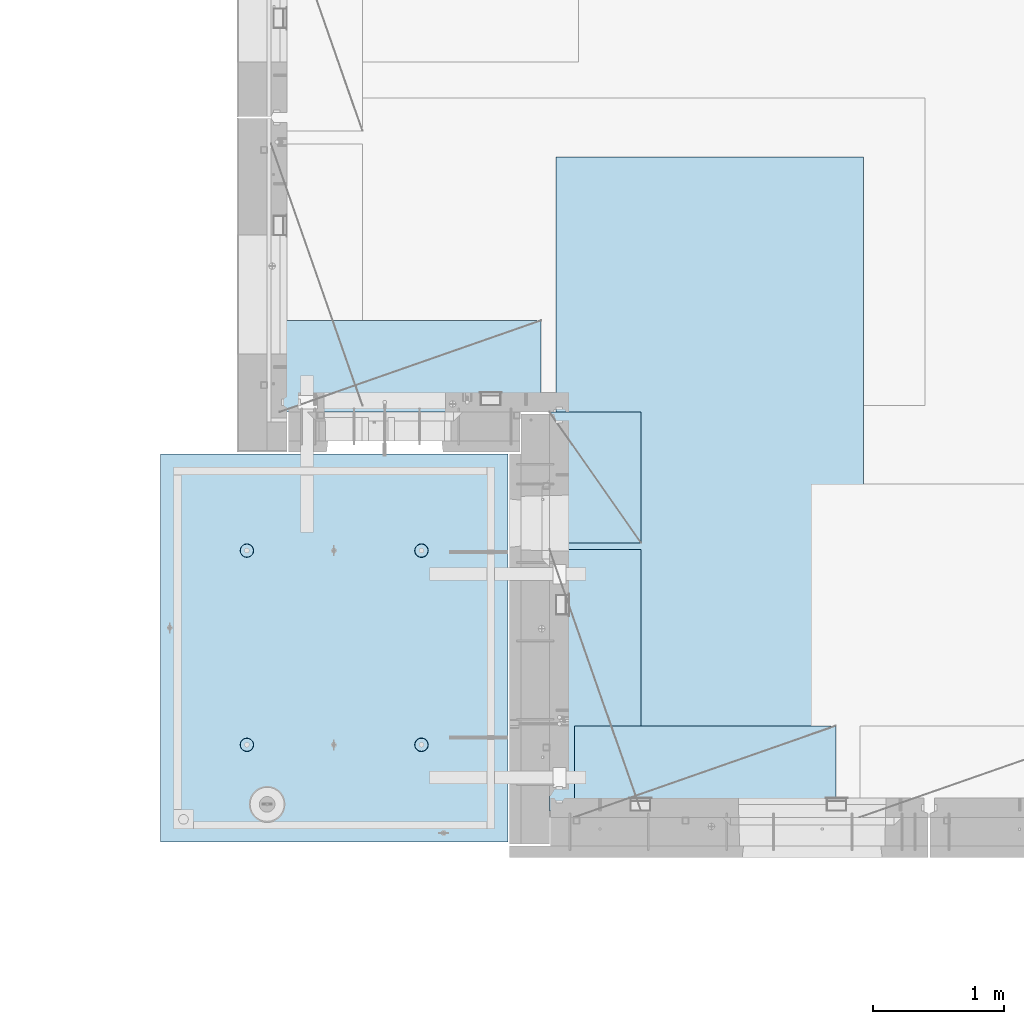
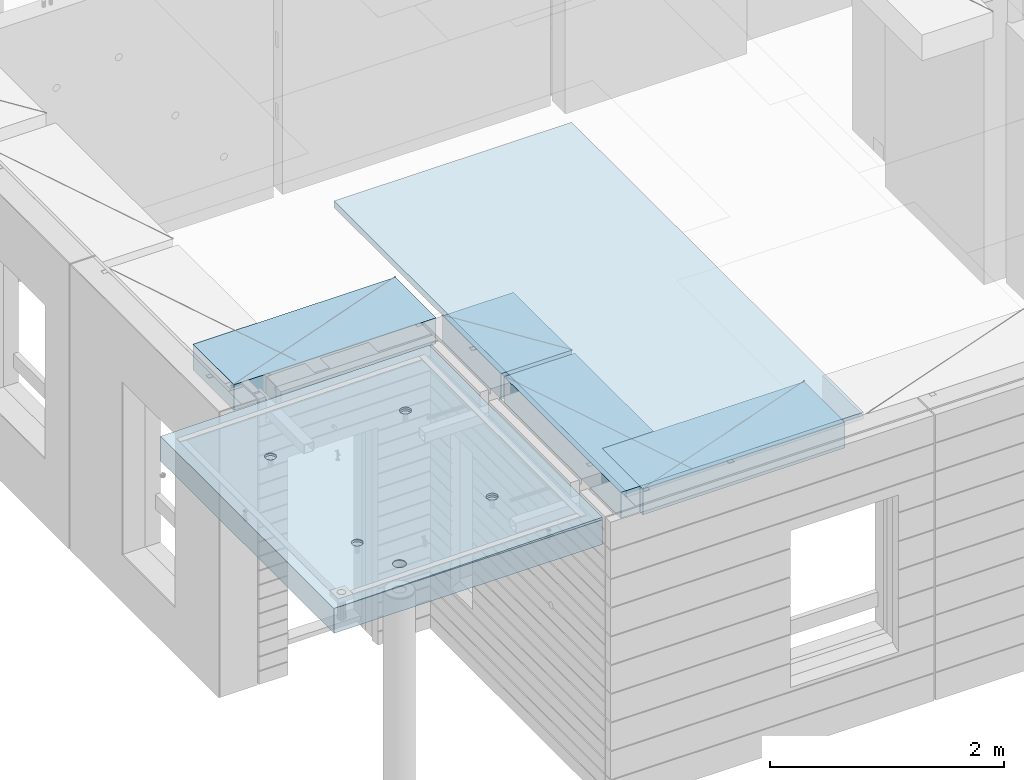
# One storey, part 199 of 349: 5 plates, 2 slabs, 6 elements without a shape of their own.
"""IFC2X3 building model written with IfcOpenShell, lengths in millimetres."""

from ifc_helpers import new_model, si_unit, frame, origin_with_axes, place, context, subcontext, project, spatial, faceted_brep, material, type_object, element, aggregate, save


model = new_model("IFC2X3")

# Units and contexts
model_context = context("Model", 3, precision=1e-05, world=origin_with_axes())
body_context = subcontext(model_context, "Body", "Model", "MODEL_VIEW")
ifc_project = project(units=[si_unit("LENGTHUNIT", "METRE", prefix="MILLI"), si_unit("AREAUNIT", "SQUARE_METRE"), si_unit("VOLUMEUNIT", "CUBIC_METRE"), si_unit("MASSUNIT", "GRAM", prefix="KILO"), si_unit("TIMEUNIT", "SECOND"), si_unit("PLANEANGLEUNIT", "RADIAN"), si_unit("SOLIDANGLEUNIT", "STERADIAN"), si_unit("THERMODYNAMICTEMPERATUREUNIT", "DEGREE_CELSIUS"), si_unit("LUMINOUSINTENSITYUNIT", "LUMEN")], contexts=[model_context])

# Site, building, storey
site_placement = place(None, origin_with_axes())
site = spatial("IfcSite", under=ifc_project, at=site_placement, CompositionType="ELEMENT")
building_placement = place(site_placement, origin_with_axes())
building = spatial("IfcBuilding", under=site, at=building_placement, CompositionType="ELEMENT")
storey_placement = place(building_placement, origin_with_axes())
storey = spatial("IfcBuildingStorey", under=building, at=storey_placement, Name="4", CompositionType="ELEMENT", Elevation=0.0)

# Assembly, slabs
assembly_1_placement = place(storey_placement, origin_with_axes())
assembly_1 = element("IfcElementAssembly", 1, at=assembly_1_placement, inside=storey, AssemblyPlace="NOTDEFINED", PredefinedType="REINFORCEMENT_UNIT")
ifc_material_1 = material(Name="CONCRETE/C35/45")
slab_type_1 = type_object("IfcSlabType", PredefinedType="NOTDEFINED")
slab_1_placement = place(assembly_1_placement, frame((9690.00344264774, 7659.99985681325, 93717.5), z_axis=(-1.0, 3.00000001838171e-08, 0.0), x_axis=(0.0, 1.0, 0.0)))
slab_1 = element("IfcSlab", 2, at=slab_1_placement, type_object=slab_type_1, material=ifc_material_1, PredefinedType="FLOOR", context=body_context, shape_type="Brep", body=[
    faceted_brep([(2970.0, 12.5, 2076.56396484375), (2970.0, 12.5, 2655.10375976563), (2970.0, 7.05330645262438, 2076.56396484375), (2970.0, 12.5, 0.0), (2969.99999999997, -12.5000027287315, -0.000215120240682154), (7.41420080885291e-08, 12.4999999999927, 0.0), (-7.41420080885291e-08, -12.5, -3.63797880709171e-12), (0.0, 12.5, 2655.00366210938), (2246.17288192116, -6.7539579669974, 610.235903379627), (2245.81872714612, 12.5, 611.325879700402), (2230.00000005311, 12.5, 608.820439463128), (2230.00000005311, -6.77809034052189, 607.672934085716), (2260.76019932669, -6.68392947182292, 617.673133503364), (2260.0890070157, 12.5, 618.596950465364), (2272.332530811, -6.57487936261168, 629.254531739907), (2271.41396524135, 12.5, 629.921908691014), (2279.75709784774, -6.43750647555862, 643.843854552742), (2278.68503600632, 12.5, 644.192188560603), (2282.30864751904, -6.2852774275234, 660.010915653605), (2281.19047624359, 12.5, 660.010915653605), (2279.73986529519, -6.13310092446045, 676.172377558725), (2278.68503600632, 12.5, 675.829642746608), (2272.30464795307, -5.995865551522, 690.747041485218), (2271.41396524135, 12.5, 690.099922616197), (2260.73231646608, -5.88698525390646, 702.310320338618), (2260.0890070157, 12.5, 701.424880841847), (2246.15564936427, -5.81709377811057, 709.732891570933), (2245.81872714612, 12.5, 708.695951606809), (2230.00000005311, -5.7930130083696, 712.290261666009), (2230.00000005311, 12.5, 711.201391844083), (2213.8443507625, -5.8170926610037, 709.732891507694), (2214.18127296011, 12.5, 708.695951606811), (2199.2676837145, -5.88698312871566, 702.310320236276), (2199.91099309052, 12.5, 701.424880841847), (2187.69535229405, -5.99586262571393, 690.747041382852), (2188.58603486487, 12.5, 690.099922616197), (2180.26013500581, -6.13309748387837, 676.172377495441), (2181.31496409991, 12.5, 675.829642746608), (2177.6913528026, -6.28527380865125, 660.010915653605), (2178.80952386264, 12.5, 660.010915653605), (2180.24290245339, -6.43750303260458, 643.843854616072), (2181.31496409991, 12.5, 644.192188560603), (2187.66746943631, -6.57487643294735, 629.254531842409), (2188.58603486487, 12.5, 629.921908691014), (2199.23980085403, -6.68392734277586, 617.673133605889), (2199.91099309052, 12.5, 618.596950465364), (2213.82711820565, -6.75395684751857, 610.235903443003), (2214.18127296011, 12.5, 611.325879700402), (761.172882674973, -6.75400078258826, 610.225900828256), (760.818727112381, 12.5, 611.315879572843), (745.000000019378, 12.5, 608.81043933557), (745.000000019378, -6.77813315729145, 607.662931409541), (775.760200790834, -6.68397228400863, 617.663131314152), (775.089006981969, 12.5, 618.586950337805), (787.33253283866, -6.57492216948594, 629.244530114656), (786.413965207619, 12.5, 629.911908563456), (794.757100236948, -6.437549275739, 643.833853637923), (793.685035972581, 12.5, 644.182188433044), (797.308650032492, -6.28532022031141, 660.000915526047), (796.190476209855, 12.5, 660.000915526047), (794.739867683551, -6.13314370981243, 676.162378218156), (793.685035972581, 12.5, 675.81964261905), (787.304649979378, -5.9959083302092, 690.737042854367), (786.413965207619, 12.5, 690.089922488638), (775.732317928869, -5.88702802728221, 702.300322270843), (775.089006981969, 12.5, 701.414880714288), (761.155650117242, -5.81713654809573, 709.722893864604), (760.818727112381, 12.5, 708.68595147925), (745.000000019378, -5.79305577717605, 712.280264084213), (745.000000019378, 12.5, 711.191391716524), (728.844349942063, -5.8171354309743, 709.722893801363), (729.181272926375, 12.5, 708.68595147925), (714.267682184241, -5.88702590207686, 702.300322168503), (714.910993056787, 12.5, 701.414880714288), (702.695350200273, -5.99590540440113, 690.737042752), (703.586034831136, 12.5, 690.089922488638), (695.260132549976, -6.1331402692449, 676.16237815487), (696.314964066174, 12.5, 675.81964261905), (692.691350221674, -6.28531660142471, 660.000915526047), (693.809523828902, 12.5, 660.000915526047), (695.242899996714, -6.43754583279951, 643.833853701251), (696.314964066174, 12.5, 644.182188433044), (702.667467341174, -6.57491923982161, 629.244530217156), (703.586034831136, 12.5, 629.911908563456), (714.239799322411, -6.68397015496157, 617.663131416677), (714.910993056787, 12.5, 618.586950337805), (728.827117384375, -6.75399966310943, 610.225900891632), (729.181272926375, 12.5, 611.315879572843), (760.941541335169, 5.82308796475991, 1945.93972725137), (760.818727091786, 12.5, 1946.31771062636), (744.999999998783, 12.5, 1943.81227038909), (744.999999998783, 5.79930078610778, 1943.4134192454), (775.320198478928, 5.89211475661432, 1953.2705735664), (775.089006961374, 12.5, 1953.58878139132), (786.72699673669, 5.99960498859582, 1964.68630888353), (786.413965187025, 12.5, 1964.91373961697), (794.045361100365, 6.13501286304381, 1979.06694274881), (793.685035951987, 12.5, 1979.18401948656), (796.560412832556, 6.28506439260673, 1995.00274657956), (796.190476189258, 12.5, 1995.00274657956), (794.028375046106, 6.43506412883289, 2010.93303130673), (793.685035951987, 12.5, 2010.82147367257), (786.699512721421, 6.57033645619231, 2025.29921596966), (786.413965187025, 12.5, 2025.09175354215), (775.292714461017, 6.67765930559835, 2036.69709108738), (775.089006961374, 12.5, 2036.41671176781), (760.924555276639, 6.74655103802797, 2044.01348819506), (760.818727091786, 12.5, 2043.68778253277), (744.999999998783, 6.7702873510425, 2046.53427709438), (744.999999998783, 12.5, 2046.19322277004), (729.075444741182, 6.7465521391714, 2044.01348813272), (729.18127290578, 12.5, 2043.68778253277), (714.70728560984, 6.67766140039021, 2036.6970909865), (714.910993036192, 12.5, 2036.41671176781), (703.300487415023, 6.57033934014908, 2025.29921586876), (703.586034810542, 12.5, 2025.09175354216), (695.971625143447, 6.43506752018584, 2010.93303124435), (696.314964045579, 12.5, 2010.82147367257), (693.439587377337, 6.28506795971771, 1995.00274657956), (693.809523808306, 12.5, 1995.00274657956), (695.954639089321, 6.13501625673962, 1979.06694281123), (696.314964045579, 12.5, 1979.18401948656), (703.273003399938, 5.99960787635064, 1964.68630898457), (703.586034810542, 12.5, 1964.91373961697), (714.679801592063, 5.89211685521877, 1953.27057366746), (714.910993036192, 12.5, 1953.58878139132), (729.058458682694, 5.82308906823164, 1945.93972731384), (729.18127290578, 12.5, 1946.31771062636), (2178.80952377932, 12.5, 1995.00274667064), (2178.43958429075, 6.28501659208268, 1995.00274667064), (2180.95463615188, 6.13496488021337, 1979.06694195729), (2181.31496401659, 12.5, 1979.18401957764), (2181.31496401659, 12.5, 2010.82147376364), (2180.97162220701, 6.43501616145659, 2010.93303228012), (2188.58603478155, 12.5, 2025.09175363323), (2188.3004849132, 6.57028798943793, 2025.29921775646), (2199.9109930072, 12.5, 2036.41671185888), (2199.70728378446, 6.6776100560528, 2036.6970935501), (2214.18127287679, 12.5, 2043.68778262385), (2214.07544376785, 6.74650079890853, 2044.0134911302), (2229.9999999698, 12.5, 2046.19322286112), (2229.9999999698, 6.77023601217661, 2046.53428024135), (2245.8187270628, 12.5, 2043.68778262385), (2245.924556192, 6.7464996977651, 2044.01349119253), (2260.08900693239, 12.5, 2036.41671185888), (2260.29271622843, 6.67760796126095, 2036.69709365098), (2271.41396515804, 12.5, 2025.09175363323), (2271.69951516527, 6.57028510548116, 2025.29921785736), (2278.685035923, 12.5, 2010.82147376364), (2279.02837792456, 6.43501277010364, 2010.9330323425), (2281.19047616027, 12.5, 1995.00274667064), (2281.56041586117, 6.2850130249717, 1995.00274667064), (2278.685035923, 12.5, 1979.18401957764), (2279.04536397983, 6.13496148651757, 1979.06694189487), (2271.41396515804, 12.5, 1964.91373970805), (2271.72699918216, 5.99955360403692, 1964.68630717681), (2260.08900693239, 12.5, 1953.5887814824), (2260.32020024797, 5.89206336568168, 1953.2705711827), (2245.8187270628, 12.5, 1946.31771071744), (2245.94154225154, 5.82303656973818, 1945.93972443295), (254.731823253564, 4.36849820162752, 1791.45731182264), (241.457918728614, 4.49348581883532, 1804.73121634759), (232.935547413403, 4.65097912067722, 1821.45731182264), (229.998938391112, 4.82556156541978, 1839.99833148514), (232.935547413403, 5.00014380698849, 1858.53935114764), (241.457918728614, 5.15763651921588, 1875.26544662269), (254.731823253564, 5.28262321809598, 1888.53935114764), (271.457918728614, 5.36286933471274, 1897.06172246285), (289.998938391112, 5.3905198200664, 1899.99833148514), (308.539958053609, 5.36286805199052, 1897.06172246285), (325.26605352866, 5.28262077822001, 1888.53935114764), (338.539958053609, 5.15763316099765, 1875.26544662269), (347.06232936882, 5.0001398591703, 1858.53935114764), (349.998938391112, 4.82555741442775, 1839.99833148514), (347.06232936882, 4.65097517284448, 1821.45731182264), (338.539958053609, 4.49348246061709, 1804.73121634759), (325.26605352866, 4.36849576173699, 1791.45731182264), (308.539958053609, 4.28824964510568, 1782.93494050743), (289.998938391112, 4.26059915976657, 1779.99833148514), (271.457918728614, 4.28825092784246, 1782.93494050743), (2199.67979976505, 5.89206546428613, 1953.27057128376), (2188.27300089649, 5.99955649179174, 1964.68630727784), (2229.9999999698, 5.79924938967451, 1943.41341627717), (2214.05845770835, 5.82303767320991, 1945.93972449542), (2188.58603478155, 12.5, 1964.91373970805), (2199.9109930072, 12.5, 1953.5887814824), (2214.18127287679, 12.5, 1946.31771071744), (2229.9999999698, 12.5, 1943.81227048017), (325.26605352866, 12.5, 1791.45731182264), (338.539958053609, 12.5, 1804.73121634759), (347.06232936882, 12.5, 1821.45731182264), (349.998938391112, 12.5, 1839.99833148514), (347.06232936882, 12.5, 1858.53935114764), (338.539958053609, 12.5, 1875.26544662269), (325.26605352866, 12.5, 1888.53935114764), (308.539958053609, 12.5, 1897.06172246285), (289.998938391112, 12.5, 1899.99833148514), (271.457918728614, 12.5, 1897.06172246285), (254.731823253564, 12.5, 1888.53935114764), (241.457918728614, 12.5, 1875.26544662269), (232.935547413403, 12.5, 1858.53935114764), (229.998938391112, 12.5, 1839.99833148514), (232.935547413403, 12.5, 1821.45731182264), (241.457918728614, 12.5, 1804.73121634759), (254.731823253564, 12.5, 1791.45731182264), (271.457918728614, 12.5, 1782.93494050743), (289.998938391112, 12.5, 1779.99833148514), (308.539958053609, 12.5, 1782.93494050743)], [[[0, 1, 2]], [[3, 0, 2, 4]], [[5, 3, 4, 6]], [[5, 6, 7]], [[8, 9, 10, 11]], [[12, 13, 9, 8]], [[14, 15, 13, 12]], [[16, 17, 15, 14]], [[18, 19, 17, 16]], [[20, 21, 19, 18]], [[21, 20, 22, 23]], [[23, 22, 24, 25]], [[25, 24, 26, 27]], [[27, 26, 28, 29]], [[29, 28, 30, 31]], [[31, 30, 32, 33]], [[33, 32, 34, 35]], [[35, 34, 36, 37]], [[37, 36, 38, 39]], [[40, 41, 39, 38]], [[42, 43, 41, 40]], [[44, 45, 43, 42]], [[46, 47, 45, 44]], [[11, 10, 47, 46]], [[48, 49, 50, 51]], [[52, 53, 49, 48]], [[54, 55, 53, 52]], [[56, 57, 55, 54]], [[58, 59, 57, 56]], [[60, 61, 59, 58]], [[61, 60, 62, 63]], [[63, 62, 64, 65]], [[65, 64, 66, 67]], [[67, 66, 68, 69]], [[69, 68, 70, 71]], [[71, 70, 72, 73]], [[73, 72, 74, 75]], [[75, 74, 76, 77]], [[77, 76, 78, 79]], [[80, 81, 79, 78]], [[82, 83, 81, 80]], [[84, 85, 83, 82]], [[86, 87, 85, 84]], [[51, 50, 87, 86]], [[88, 89, 90, 91]], [[92, 93, 89, 88]], [[94, 95, 93, 92]], [[96, 97, 95, 94]], [[98, 99, 97, 96]], [[100, 101, 99, 98]], [[102, 103, 101, 100]], [[104, 105, 103, 102]], [[105, 104, 106, 107]], [[107, 106, 108, 109]], [[109, 108, 110, 111]], [[111, 110, 112, 113]], [[113, 112, 114, 115]], [[115, 114, 116, 117]], [[117, 116, 118, 119]], [[119, 118, 120, 121]], [[121, 120, 122, 123]], [[124, 125, 123, 122]], [[126, 127, 125, 124]], [[91, 90, 127, 126]], [[128, 129, 130, 131]], [[132, 133, 129, 128]], [[134, 135, 133, 132]], [[136, 137, 135, 134]], [[138, 139, 137, 136]], [[140, 141, 139, 138]], [[142, 143, 141, 140]], [[144, 145, 143, 142]], [[145, 144, 146, 147]], [[147, 146, 148, 149]], [[149, 148, 150, 151]], [[151, 150, 152, 153]], [[153, 152, 154, 155]], [[155, 154, 156, 157]], [[157, 156, 158, 159]], [[4, 2, 1, 7, 6], [160, 161, 162, 163, 164, 165, 166, 167, 168, 169, 170, 171, 172, 173, 174, 175, 176, 177, 178, 179], [180, 181, 130, 129, 133, 135, 137, 139, 141, 143, 145, 147, 149, 151, 153, 155, 157, 159, 182, 183], [124, 122, 120, 118, 116, 114, 112, 110, 108, 106, 104, 102, 100, 98, 96, 94, 92, 88, 91, 126], [84, 82, 80, 78, 76, 74, 72, 70, 68, 66, 64, 62, 60, 58, 56, 54, 52, 48, 51, 86], [44, 42, 40, 38, 36, 34, 32, 30, 28, 26, 24, 22, 20, 18, 16, 14, 12, 8, 11, 46]], [[131, 130, 181, 184]], [[180, 185, 184, 181]], [[183, 186, 185, 180]], [[182, 187, 186, 183]], [[159, 158, 187, 182]], [[0, 3, 5, 7, 1], [188, 189, 190, 191, 192, 193, 194, 195, 196, 197, 198, 199, 200, 201, 202, 203, 204, 205, 206, 207], [156, 154, 152, 150, 148, 146, 144, 142, 140, 138, 136, 134, 132, 128, 131, 184, 185, 186, 187, 158], [93, 95, 97, 99, 101, 103, 105, 107, 109, 111, 113, 115, 117, 119, 121, 123, 125, 127, 90, 89], [53, 55, 57, 59, 61, 63, 65, 67, 69, 71, 73, 75, 77, 79, 81, 83, 85, 87, 50, 49], [13, 15, 17, 19, 21, 23, 25, 27, 29, 31, 33, 35, 37, 39, 41, 43, 45, 47, 10, 9]], [[178, 206, 205, 179]], [[177, 207, 206, 178]], [[176, 188, 207, 177]], [[175, 189, 188, 176]], [[174, 190, 189, 175]], [[173, 191, 190, 174]], [[172, 192, 191, 173]], [[171, 193, 192, 172]], [[170, 194, 193, 171]], [[169, 195, 194, 170]], [[168, 196, 195, 169]], [[167, 197, 196, 168]], [[166, 198, 197, 167]], [[165, 199, 198, 166]], [[164, 200, 199, 165]], [[163, 201, 200, 164]], [[162, 202, 201, 163]], [[161, 203, 202, 162]], [[160, 204, 203, 161]], [[179, 205, 204, 160]]]),
])
slab_type_2 = type_object("IfcSlabType", PredefinedType="NOTDEFINED")
slab_2_placement = place(assembly_1_placement, frame((9690.00344264774, 7659.99985681325, 93575.0), z_axis=(-0.999999999997437, -2.26400000064461e-06, 0.0), x_axis=(-2.2639999995273e-06, 0.999999999997437, 0.0)))
slab_2 = element("IfcSlab", 3, at=slab_2_placement, type_object=slab_type_2, material=ifc_material_1, PredefinedType="FLOOR", context=body_context, shape_type="Brep", body=[
    faceted_brep([(2245.45536387143, -110.0, 1947.44471589559), (2259.39379322965, -110.0, 1954.54665968234), (2270.4554059745, -110.0, 1965.60822114567), (2277.55741437973, -110.0, 1979.54661757913), (2280.00462438004, -110.0, 1994.99746162528), (2277.55748600988, -110.0, 2010.44831701654), (2270.45554222312, -110.0, 2024.38674637476), (2259.39398075979, -110.0, 2035.44835911961), (2245.45558432633, -110.0, 2042.55036752485), (2230.00474028018, -110.0, 2044.99757752515), (2214.55388488892, -110.0, 2042.55043915498), (2200.6154555307, -110.0, 2035.44849536823), (2189.55384278585, -110.0, 2024.3869339049), (2182.45183438062, -110.0, 2010.44853747144), (2180.00462438031, -110.0, 1994.99769342529), (2182.45176275048, -110.0, 1979.54683803403), (2189.55370653723, -110.0, 1965.60840867581), (2200.61526800056, -110.0, 1954.54679593096), (2214.55366443402, -110.0, 1947.44478752572), (2230.00450848018, -110.0, 1944.99757752542), (2260.09353534512, -130.0, 1953.58354259084), (2245.82323862122, -130.0, 1946.3125049044), (2271.41851982199, -130.0, 1964.9084745652), (2278.68962366544, -130.0, 1979.17873758041), (2281.19510057052, -130.0, 1994.99745886576), (2278.68969700106, -130.0, 2010.81619176633), (2271.41865931462, -130.0, 2025.08648849022), (2260.09372734026, -130.0, 2036.4114729671), (2245.82346432505, -130.0, 2043.68257681055), (2230.0047430397, -130.0, 2046.18805371562), (2214.18601013913, -130.0, 2043.68265014617), (2199.91571341524, -130.0, 2036.41161245973), (2188.59072893836, -130.0, 2025.08668048537), (2181.31962509491, -130.0, 2010.81641747016), (2178.81414818984, -130.0, 1994.99769618481), (2181.31955175929, -130.0, 1979.17896328424), (2188.59058944573, -130.0, 1964.90866656035), (2199.91552142009, -130.0, 1953.58368208347), (2214.1857844353, -130.0, 1946.31257824002), (2230.00450572065, -130.0, 1943.80710133495), (760.455363904408, -110.0, 1947.44815803451), (774.393793262629, -110.0, 1954.55010182126), (785.455406007481, -110.0, 1965.61166328459), (792.557414412711, -110.0, 1979.55005971805), (795.004624413019, -110.0, 1995.00090376421), (792.557486042851, -110.0, 2010.45175915546), (785.455542256102, -110.0, 2024.39018851368), (774.393980792767, -110.0, 2035.45180125853), (760.455584359308, -110.0, 2042.55380966377), (745.004740313152, -110.0, 2045.00101966407), (729.553884921896, -110.0, 2042.55388129391), (715.615455563677, -110.0, 2035.45193750716), (704.553842818825, -110.0, 2024.39037604382), (697.451834413594, -110.0, 2010.45197961036), (695.004624413286, -110.0, 1995.00113556421), (697.451762783454, -110.0, 1979.55028017295), (704.553706570203, -110.0, 1965.61185081473), (715.615268033538, -110.0, 1954.55023806988), (729.553664466996, -110.0, 1947.44822966465), (745.004508513151, -110.0, 1945.00101966434), (760.823238654199, -130.0, 1946.31594704332), (745.004505753628, -130.0, 1943.81054347387), (775.093535378091, -130.0, 1953.58698472976), (786.418519854964, -130.0, 1964.91191670413), (793.689623698416, -130.0, 1979.18217971933), (796.195100603492, -130.0, 1995.00090100468), (793.689697034035, -130.0, 2010.81963390525), (786.418659347601, -130.0, 2025.08993062915), (775.093727373234, -130.0, 2036.41491510602), (760.823464358025, -130.0, 2043.68601894947), (745.004743072675, -130.0, 2046.19149585455), (729.186010172105, -130.0, 2043.68609228509), (714.915713448214, -130.0, 2036.41505459866), (703.590728971341, -130.0, 2025.09012262429), (696.319625127888, -130.0, 2010.81985960908), (693.814148222813, -130.0, 1995.00113832373), (696.319551792269, -130.0, 1979.18240542316), (703.590589478705, -130.0, 1964.91210869927), (714.915521453071, -130.0, 1953.5871242224), (729.185784468278, -130.0, 1946.31602037894), (2970.0, -130.0, 1.11504050437361e-09), (0.0, -130.0, -3.63797880709171e-12), (0.0, 130.0, -1.81898940354586e-12), (2970.0, 130.0, 1.11504050437361e-09), (2970.0048828125, -130.0, 2076.55712890625), (2970.0048828125, 130.0, 2076.55712890625), (2970.00610351563, -130.0, 2655.0966796875), (2970.00610351563, 130.0, 2655.0966796875), (0.00277573079893045, -130.0, 2655.00366210937), (0.00277573079893045, 130.0, 2655.00366210937), (325.270206125839, 130.0, 1791.45655785112), (338.544141419662, 130.0, 1804.73043160713), (347.066551505941, 130.0, 1821.45650732727), (350.003203506308, 130.0, 1839.99752018266), (347.066637462108, 130.0, 1858.53854665217), (338.544304918008, 130.0, 1875.26466188203), (325.270431162006, 130.0, 1888.53859717586), (308.544355441856, 130.0, 1897.06100726213), (290.003342586469, 130.0, 1899.9976592625), (271.462316116962, 130.0, 1897.0610932183), (254.7362008871, 130.0, 1888.5387606742), (241.462265593274, 130.0, 1875.2648869182), (232.939855506997, 130.0, 1858.53881119805), (230.00320350663, 130.0, 1839.99779834266), (232.93976955083, 130.0, 1821.45677187316), (241.462102094929, 130.0, 1804.73065664329), (254.735975850932, 130.0, 1791.45672134947), (271.462051571081, 130.0, 1782.93431126319), (290.003064426469, 130.0, 1779.99765926282), (308.544090895975, 130.0, 1782.93422530702), (308.544090895975, -130.0, 1782.93422530702), (290.003064426469, -130.0, 1779.99765926282), (325.270206125839, -130.0, 1791.45655785112), (338.544141419662, -130.0, 1804.73043160713), (347.066551505941, -130.0, 1821.45650732727), (350.003203506308, -130.0, 1839.99752018266), (347.066637462108, -130.0, 1858.53854665217), (338.544304918008, -130.0, 1875.26466188203), (325.270431162006, -130.0, 1888.53859717586), (308.544355441856, -130.0, 1897.06100726213), (290.003342586469, -130.0, 1899.9976592625), (271.462316116962, -130.0, 1897.0610932183), (254.7362008871, -130.0, 1888.5387606742), (241.462265593274, -130.0, 1875.2648869182), (232.939855506997, -130.0, 1858.53881119805), (230.00320350663, -130.0, 1839.99779834266), (232.93976955083, -130.0, 1821.45677187316), (241.462102094929, -130.0, 1804.73065664329), (254.735975850932, -130.0, 1791.45672134947), (271.462051571081, -130.0, 1782.93431126319), (760.452269390758, -110.0, 612.446326984578), (774.390698748979, -110.0, 619.548270771327), (785.452311493831, -110.0, 630.609832234661), (792.554319899062, -110.0, 644.54822866812), (795.001529899369, -110.0, 659.999072714278), (792.554391529202, -110.0, 675.449928105532), (785.452447742453, -110.0, 689.388357463751), (774.390886279118, -110.0, 700.449970208605), (760.452489845658, -110.0, 707.551978613836), (745.001645799503, -110.0, 709.999188614142), (729.550790408246, -110.0, 707.552050243974), (715.612361050027, -110.0, 700.450106457225), (704.550748305175, -110.0, 689.388544993892), (697.448739899944, -110.0, 675.450148560432), (695.001529899637, -110.0, 659.999304514276), (697.448668269804, -110.0, 644.54844912302), (704.550612056553, -110.0, 630.610019764801), (715.612173519889, -110.0, 619.548407019947), (729.550569953346, -110.0, 612.446398614717), (745.001413999502, -110.0, 609.999188614411), (760.820144140549, -130.0, 611.314115993395), (745.001411239979, -130.0, 608.808712423936), (775.090440864442, -130.0, 618.585153679829), (786.415425341314, -130.0, 629.910085654195), (793.686529184766, -130.0, 644.180348669403), (796.192006089843, -130.0, 659.999069954752), (793.686602520385, -130.0, 675.817802855323), (786.415564833951, -130.0, 690.088099579216), (775.090632859585, -130.0, 701.41308405609), (760.820369844376, -130.0, 708.68418789954), (745.001648559026, -130.0, 711.189664804615), (729.182915658455, -130.0, 708.684261235159), (714.912618934564, -130.0, 701.413223548725), (703.587634457692, -130.0, 690.088291574357), (696.316530614238, -130.0, 675.81802855915), (693.811053709163, -130.0, 659.999307273802), (696.316457278619, -130.0, 644.180574373229), (703.587494965055, -130.0, 629.910277649336), (714.912426939421, -130.0, 618.585293172464), (729.182689954629, -130.0, 611.314189329014), (2245.45226944368, -110.0, 612.452884882137), (2259.3906988019, -110.0, 619.554828668886), (2270.45231154675, -110.0, 630.61639013222), (2277.55431995199, -110.0, 644.554786565679), (2280.00152995229, -110.0, 660.005630611837), (2277.55439158212, -110.0, 675.456486003091), (2270.45244779537, -110.0, 689.39491536131), (2259.39088633204, -110.0, 700.456528106164), (2245.45248989858, -110.0, 707.558536511395), (2230.00164585242, -110.0, 710.005746511701), (2214.55079046117, -110.0, 707.558608141533), (2200.61236110295, -110.0, 700.456664354784), (2189.5507483581, -110.0, 689.395102891451), (2182.44873995286, -110.0, 675.456706457991), (2180.00152995256, -110.0, 660.005862411836), (2182.44866832273, -110.0, 644.555007020579), (2189.55061210948, -110.0, 630.61657766236), (2200.61217357281, -110.0, 619.554964917506), (2214.55057000627, -110.0, 612.452956512276), (2230.00141405243, -110.0, 610.00574651197), (2245.82014419347, -130.0, 611.320673890954), (2230.0014112929, -130.0, 608.815270321495), (2260.09044091736, -130.0, 618.591711577388), (2271.41542539424, -130.0, 629.916643551753), (2278.68652923769, -130.0, 644.186906566962), (2281.19200614276, -130.0, 660.005627852312), (2278.68660257331, -130.0, 675.824360752882), (2271.41556488687, -130.0, 690.094657476773), (2260.09063291251, -130.0, 701.419641953647), (2245.8203698973, -130.0, 708.690745797099), (2230.00164861195, -130.0, 711.196222702174), (2214.18291571138, -130.0, 708.690819132718), (2199.91261898749, -130.0, 701.419781446282), (2188.58763451061, -130.0, 690.094849471916), (2181.31653066716, -130.0, 675.824586456709), (2178.81105376209, -130.0, 660.005865171361), (2181.31645733154, -130.0, 644.187132270788), (2188.58749501798, -130.0, 629.916835546896), (2199.91242699234, -130.0, 618.591851070023), (2214.18269000755, -130.0, 611.320747226573)], [[[0, 1, 2, 3, 4, 5, 6, 7, 8, 9, 10, 11, 12, 13, 14, 15, 16, 17, 18, 19]], [[20, 1, 0, 21]], [[22, 2, 1, 20]], [[23, 3, 2, 22]], [[24, 4, 3, 23]], [[25, 5, 4, 24]], [[26, 6, 5, 25]], [[27, 7, 6, 26]], [[28, 8, 7, 27]], [[29, 9, 8, 28]], [[30, 10, 9, 29]], [[31, 11, 10, 30]], [[32, 12, 11, 31]], [[33, 13, 12, 32]], [[34, 14, 13, 33]], [[35, 15, 14, 34]], [[36, 16, 15, 35]], [[37, 17, 16, 36]], [[38, 18, 17, 37]], [[39, 19, 18, 38]], [[21, 0, 19, 39]], [[40, 41, 42, 43, 44, 45, 46, 47, 48, 49, 50, 51, 52, 53, 54, 55, 56, 57, 58, 59]], [[60, 40, 59, 61]], [[62, 41, 40, 60]], [[63, 42, 41, 62]], [[64, 43, 42, 63]], [[65, 44, 43, 64]], [[66, 45, 44, 65]], [[67, 46, 45, 66]], [[68, 47, 46, 67]], [[69, 48, 47, 68]], [[70, 49, 48, 69]], [[71, 50, 49, 70]], [[72, 51, 50, 71]], [[73, 52, 51, 72]], [[74, 53, 52, 73]], [[75, 54, 53, 74]], [[76, 55, 54, 75]], [[77, 56, 55, 76]], [[78, 57, 56, 77]], [[79, 58, 57, 78]], [[61, 59, 58, 79]], [[80, 81, 82, 83]], [[84, 80, 83, 85]], [[86, 84, 85, 87]], [[88, 86, 87, 89]], [[81, 88, 89, 82]], [[87, 85, 83, 82, 89], [90, 91, 92, 93, 94, 95, 96, 97, 98, 99, 100, 101, 102, 103, 104, 105, 106, 107, 108, 109]], [[110, 109, 108, 111]], [[112, 90, 109, 110]], [[113, 91, 90, 112]], [[114, 92, 91, 113]], [[115, 93, 92, 114]], [[116, 94, 93, 115]], [[117, 95, 94, 116]], [[118, 96, 95, 117]], [[119, 97, 96, 118]], [[120, 98, 97, 119]], [[121, 99, 98, 120]], [[122, 100, 99, 121]], [[123, 101, 100, 122]], [[124, 102, 101, 123]], [[125, 103, 102, 124]], [[126, 104, 103, 125]], [[127, 105, 104, 126]], [[128, 106, 105, 127]], [[129, 107, 106, 128]], [[111, 108, 107, 129]], [[130, 131, 132, 133, 134, 135, 136, 137, 138, 139, 140, 141, 142, 143, 144, 145, 146, 147, 148, 149]], [[150, 130, 149, 151]], [[152, 131, 130, 150]], [[153, 132, 131, 152]], [[154, 133, 132, 153]], [[155, 134, 133, 154]], [[156, 135, 134, 155]], [[157, 136, 135, 156]], [[158, 137, 136, 157]], [[159, 138, 137, 158]], [[160, 139, 138, 159]], [[161, 140, 139, 160]], [[162, 141, 140, 161]], [[163, 142, 141, 162]], [[164, 143, 142, 163]], [[165, 144, 143, 164]], [[166, 145, 144, 165]], [[167, 146, 145, 166]], [[168, 147, 146, 167]], [[169, 148, 147, 168]], [[151, 149, 148, 169]], [[170, 171, 172, 173, 174, 175, 176, 177, 178, 179, 180, 181, 182, 183, 184, 185, 186, 187, 188, 189]], [[190, 170, 189, 191]], [[192, 171, 170, 190]], [[193, 172, 171, 192]], [[194, 173, 172, 193]], [[195, 174, 173, 194]], [[196, 175, 174, 195]], [[197, 176, 175, 196]], [[198, 177, 176, 197]], [[199, 178, 177, 198]], [[200, 179, 178, 199]], [[201, 180, 179, 200]], [[202, 181, 180, 201]], [[203, 182, 181, 202]], [[204, 183, 182, 203]], [[205, 184, 183, 204]], [[206, 185, 184, 205]], [[207, 186, 185, 206]], [[208, 187, 186, 207]], [[209, 188, 187, 208]], [[191, 189, 188, 209]], [[80, 84, 86, 88, 81], [37, 36, 35, 34, 33, 32, 31, 30, 29, 28, 27, 26, 25, 24, 23, 22, 20, 21, 39, 38], [208, 207, 206, 205, 204, 203, 202, 201, 200, 199, 198, 197, 196, 195, 194, 193, 192, 190, 191, 209], [168, 167, 166, 165, 164, 163, 162, 161, 160, 159, 158, 157, 156, 155, 154, 153, 152, 150, 151, 169], [128, 127, 126, 125, 124, 123, 122, 121, 120, 119, 118, 117, 116, 115, 114, 113, 112, 110, 111, 129], [78, 77, 76, 75, 74, 73, 72, 71, 70, 69, 68, 67, 66, 65, 64, 63, 62, 60, 61, 79]]]),
])
aggregate(assembly_1, [slab_1, slab_2])

# Assembly, plate
assembly_2_placement = place(storey_placement, origin_with_axes())
assembly_2 = element("IfcElementAssembly", 4, at=assembly_2_placement, inside=storey, Name="Steel Assembly", AssemblyPlace="NOTDEFINED", PredefinedType="NOTDEFINED")
ifc_material_2 = material()
plate_type_1 = type_object("IfcPlateType", PredefinedType="NOTDEFINED")
plate_1_placement = place(assembly_2_placement, frame((10060.0, 7900.0, 93695.1), z_axis=(0.0, 1.0, 0.0), x_axis=(1.0, 0.0, 0.0)))
plate_1 = element("IfcPlate", 5, at=plate_1_placement, type_object=plate_type_1, material=ifc_material_2, context=body_context, shape_type="Brep", body=[
    faceted_brep([(0.0, -35.0, 0.0), (0.0, -35.0, 5000.0), (0.0, 35.0, 5000.0), (0.0, 35.0, 0.0), (2349.99951171875, -35.0, 5000.0), (2349.99951171875, 35.0, 5000.0), (2350.0, -35.0, 0.0), (2350.0, 35.0, 0.0)], [[[0, 1, 2, 3]], [[1, 4, 5, 2]], [[4, 6, 7, 5]], [[6, 0, 3, 7]], [[5, 7, 3, 2]], [[6, 4, 1, 0]]]),
])
aggregate(assembly_2, [plate_1])

assembly_3_placement = place(storey_placement, origin_with_axes())
assembly_3 = element("IfcElementAssembly", 6, at=assembly_3_placement, inside=storey, Name="Steel Assembly", AssemblyPlace="NOTDEFINED", PredefinedType="NOTDEFINED")
plate_type_2 = type_object("IfcPlateType", PredefinedType="NOTDEFINED")
plate_2_placement = place(assembly_3_placement, frame((7945.00085423865, 10950.0001036336, 93595.3), z_axis=(0.0, 1.0, 0.0), x_axis=(1.0, 0.0, 0.0)))
plate_2 = element("IfcPlate", 7, at=plate_2_placement, type_object=plate_type_2, material=ifc_material_2, Name="RE1", context=body_context, shape_type="Brep", body=[
    faceted_brep([(1.81898940354586e-12, -135.0, 1.81898940354586e-12), (0.0, -135.0, 699.999999999996), (0.0, 135.0, 699.999999999996), (1.81898940354586e-12, 135.0, 1.81898940354586e-12), (1999.99951171875, -135.0, 699.999999999993), (1999.99951171875, 135.0, 699.999999999993), (2000.0, -135.0, -3.63797880709171e-12), (2000.0, 135.0, -3.63797880709171e-12)], [[[0, 1, 2, 3]], [[1, 4, 5, 2]], [[4, 6, 7, 5]], [[6, 0, 3, 7]], [[5, 7, 3, 2]], [[6, 4, 1, 0]]]),
])
aggregate(assembly_3, [plate_2])

assembly_4_placement = place(storey_placement, origin_with_axes())
assembly_4 = element("IfcElementAssembly", 8, at=assembly_4_placement, inside=storey, Name="Steel Assembly", AssemblyPlace="NOTDEFINED", PredefinedType="NOTDEFINED")
plate_3_placement = place(assembly_4_placement, frame((10009.9998779297, 9900.0, 93595.3), z_axis=(1.0, 0.0, 0.0), x_axis=(0.0, -1.0, 0.0)))
plate_3 = element("IfcPlate", 9, at=plate_3_placement, type_object=plate_type_2, material=ifc_material_2, Name="RE1", context=body_context, shape_type="Brep", body=[
    faceted_brep([(1.81898940354586e-12, -135.0, 1.81898940354586e-12), (0.0, -135.0, 699.999999999996), (0.0, 135.0, 699.999999999996), (1.81898940354586e-12, 135.0, 1.81898940354586e-12), (1999.99951171875, -135.0, 699.999999999993), (1999.99951171875, 135.0, 699.999999999993), (2000.0, -135.0, -3.63797880709171e-12), (2000.0, 135.0, -3.63797880709171e-12)], [[[0, 1, 2, 3]], [[1, 4, 5, 2]], [[4, 6, 7, 5]], [[6, 0, 3, 7]], [[5, 7, 3, 2]], [[6, 4, 1, 0]]]),
])
aggregate(assembly_4, [plate_3])

assembly_5_placement = place(storey_placement, origin_with_axes())
assembly_5 = element("IfcElementAssembly", 10, at=assembly_5_placement, inside=storey, Name="Steel Assembly", AssemblyPlace="NOTDEFINED", PredefinedType="NOTDEFINED")
plate_4_placement = place(assembly_5_placement, frame((10009.9999999293, 10950.0, 93595.3), z_axis=(1.0, 0.0, 0.0), x_axis=(0.0, -1.0, 0.0)))
plate_4 = element("IfcPlate", 11, at=plate_4_placement, type_object=plate_type_2, material=ifc_material_2, Name="RE1_1/2", context=body_context, shape_type="Brep", body=[
    faceted_brep([(1.81898940354586e-12, -135.0, 1.81898940354586e-12), (0.0, -135.0, 699.999999999996), (0.0, 135.0, 699.999999999996), (1.81898940354586e-12, 135.0, 1.81898940354586e-12), (999.99951171875, -135.0, 700.0), (999.99951171875, 135.0, 700.0), (1000.0, -135.0, 0.0), (1000.0, 135.0, 0.0)], [[[0, 1, 2, 3]], [[1, 4, 5, 2]], [[4, 6, 7, 5]], [[6, 0, 3, 7]], [[5, 7, 3, 2]], [[6, 4, 1, 0]]]),
])
aggregate(assembly_5, [plate_4])

assembly_6_placement = place(storey_placement, origin_with_axes())
assembly_6 = element("IfcElementAssembly", 12, at=assembly_6_placement, inside=storey, Name="Steel Assembly", AssemblyPlace="NOTDEFINED", PredefinedType="NOTDEFINED")
plate_5_placement = place(assembly_6_placement, frame((10200.0008542386, 7850.00010363356, 93595.3), z_axis=(0.0, 1.0, 0.0), x_axis=(1.0, 0.0, 0.0)))
plate_5 = element("IfcPlate", 13, at=plate_5_placement, type_object=plate_type_2, material=ifc_material_2, Name="RE1", context=body_context, shape_type="Brep", body=[
    faceted_brep([(1.81898940354586e-12, -135.0, 1.81898940354586e-12), (0.0, -135.0, 699.999999999996), (0.0, 135.0, 699.999999999996), (1.81898940354586e-12, 135.0, 1.81898940354586e-12), (1999.99951171875, -135.0, 699.999999999993), (1999.99951171875, 135.0, 699.999999999993), (2000.0, -135.0, -3.63797880709171e-12), (2000.0, 135.0, -3.63797880709171e-12)], [[[0, 1, 2, 3]], [[1, 4, 5, 2]], [[4, 6, 7, 5]], [[6, 0, 3, 7]], [[5, 7, 3, 2]], [[6, 4, 1, 0]]]),
])
aggregate(assembly_6, [plate_5])

save(model, "model.ifc")
